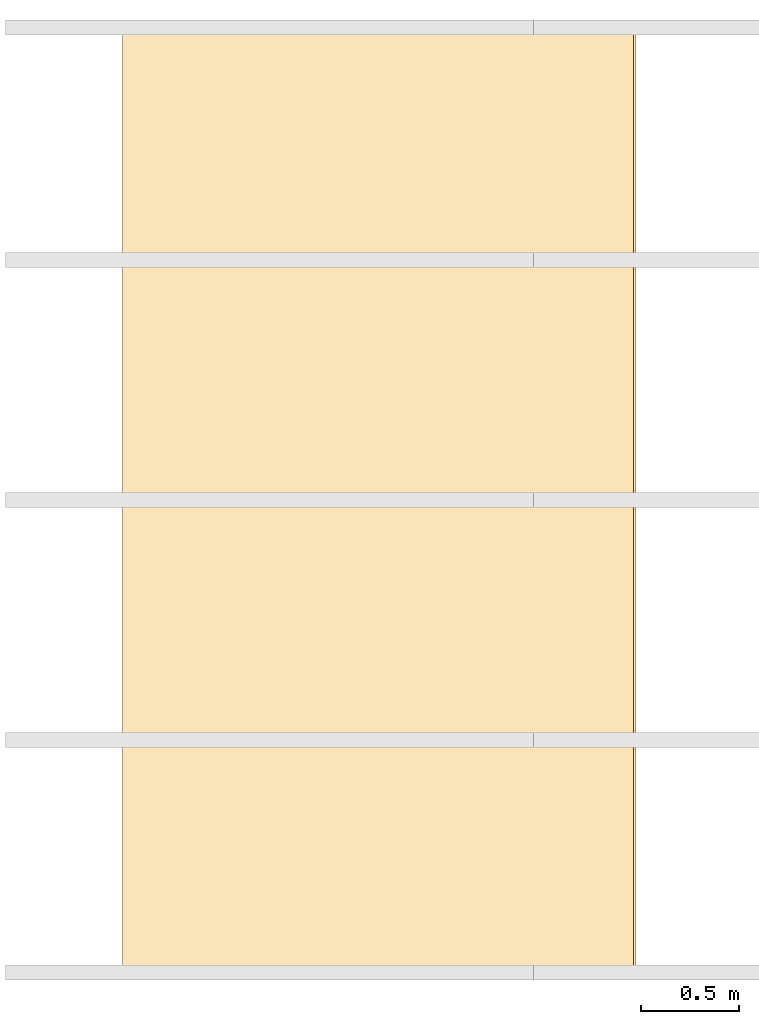
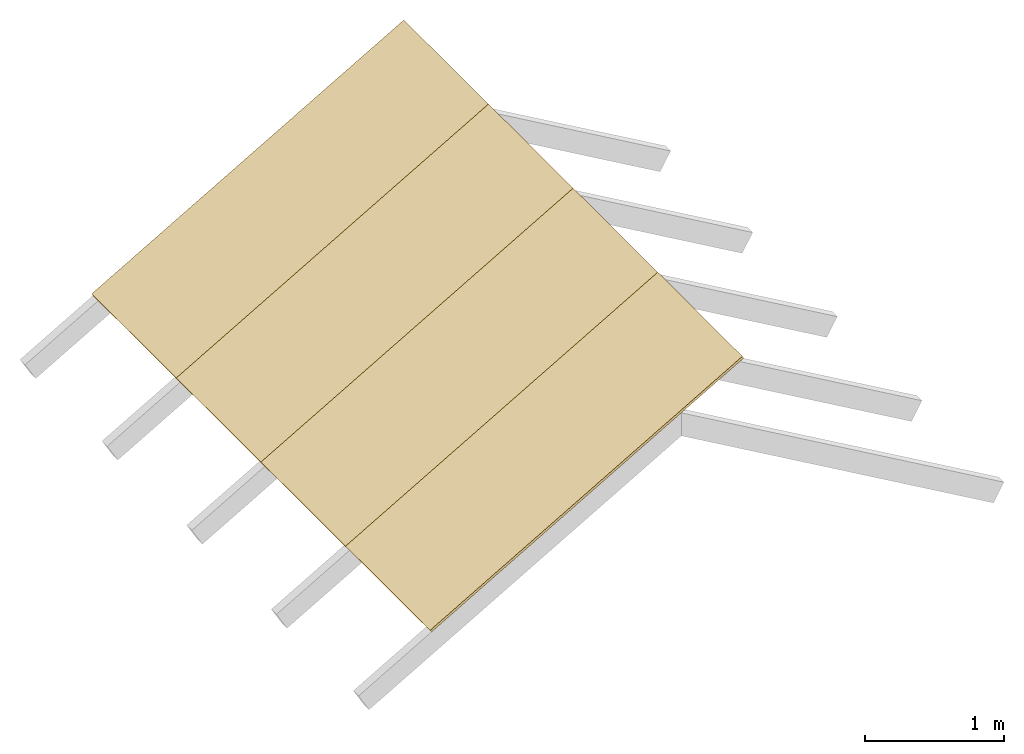
# One storey, part 2 of 2: 4 coverings.
"""IFC4 building model written with IfcOpenShell, lengths in millimetres."""

from ifc_helpers import new_model, entity, si_unit, converted_unit, frame, frame_2d, origin_with_axes, place, context, subcontext, project, spatial, rectangle, extrude, material, material_profile, profile_set, profile_usage, type_object, element, save


model = new_model("IFC4")

# Units and contexts
model_context = context("Model", 3, precision=1e-05, world=origin_with_axes())
plan_context = context("Plan", 2, precision=1e-05, world=frame_2d((0.0, 0.0, 0.0), x_axis=(1.0, 0.0, 0.0)))
body_context = subcontext(model_context, "Body", "Model", "MODEL_VIEW")
ifc_project = project(units=[converted_unit("PLANEANGLEUNIT", "degree", entity("IfcReal", 0.0174532925199433), si_unit("PLANEANGLEUNIT", "RADIAN"), dimensions=[0, 0, 0, 0, 0, 0, 0]), si_unit("AREAUNIT", "SQUARE_METRE", prefix="MILLI"), si_unit("VOLUMEUNIT", "CUBIC_METRE", prefix="MILLI"), si_unit("LENGTHUNIT", "METRE", prefix="MILLI")], contexts=[model_context, plan_context])

# Site, building, storey
site_placement = place(None, origin_with_axes())
site = spatial("IfcSite", under=ifc_project, at=site_placement)
building_placement = place(site_placement, origin_with_axes())
building = spatial("IfcBuilding", under=site, at=building_placement, Name="Building")
storey_placement = place(building_placement, origin_with_axes())
storey = spatial("IfcBuildingStorey", under=building, at=storey_placement, Name="Storey")

# Coverings
ifc_material = material(Name="underlayment")
ifc_material_profile = material_profile(ifc_material, rectangle(XDim=1220.0, YDim=22.0))
ifc_profile_set = profile_set([ifc_material_profile])
ifc_profile_usage_1 = profile_usage(ifc_profile_set, cardinal=1)
covering_type = type_object("IfcCoveringType", Name="underlayment_2440x1220x22mm", PredefinedType="CLADDING", material=ifc_profile_set)
covering_1_placement = place(storey_placement, frame((519.615054130554, 1145.00021934509, 502.073228359222), z_axis=(0.866025686264038, 8.06965587685227e-08, 0.499999552965164), x_axis=(-1.62920684942947e-07, 1.0, 1.20793970381783e-07)))
element("IfcCovering", 1, at=covering_1_placement, inside=storey, type_object=covering_type, material=ifc_profile_usage_1, Name="Covering", PredefinedType="NOTDEFINED", context=body_context, shape_type="SweptSolid", body=[
    extrude(rectangle(XDim=1220.0, YDim=22.0), frame((-610.0, 11.0, 0.0), z_axis=(0.0, 0.0, 1.0), x_axis=(1.0, 0.0, 0.0)), (0.0, 0.0, 1.0), 3000.0),
])
ifc_profile_usage_2 = profile_usage(ifc_profile_set, cardinal=1)
covering_2_placement = place(storey_placement, frame((519.614815711975, 2365.00024795532, 502.073347568512), z_axis=(0.866025686264038, 8.06965587685227e-08, 0.499999552965164), x_axis=(-1.62920684942947e-07, 1.0, 1.20793970381783e-07)))
element("IfcCovering", 2, at=covering_2_placement, inside=storey, type_object=covering_type, material=ifc_profile_usage_2, Name="Covering", PredefinedType="NOTDEFINED", context=body_context, shape_type="SweptSolid", body=[
    extrude(rectangle(XDim=1220.0, YDim=22.0), frame((-610.0, 11.0, 0.0), z_axis=(0.0, 0.0, 1.0), x_axis=(1.0, 0.0, 0.0)), (0.0, 0.0, 1.0), 3000.0),
])
ifc_profile_usage_3 = profile_usage(ifc_profile_set, cardinal=1)
covering_3_placement = place(storey_placement, frame((519.614517688751, 3585.00003814697, 502.073585987091), z_axis=(0.866025686264038, 8.06965587685227e-08, 0.499999552965164), x_axis=(-1.62920684942947e-07, 1.0, 1.20793970381783e-07)))
element("IfcCovering", 3, at=covering_3_placement, inside=storey, type_object=covering_type, material=ifc_profile_usage_3, Name="Covering", PredefinedType="NOTDEFINED", context=body_context, shape_type="SweptSolid", body=[
    extrude(rectangle(XDim=1220.0, YDim=22.0), frame((-610.0, 11.0, 0.0), z_axis=(0.0, 0.0, 1.0), x_axis=(1.0, 0.0, 0.0)), (0.0, 0.0, 1.0), 3000.0),
])
ifc_profile_usage_4 = profile_usage(ifc_profile_set, cardinal=1)
covering_4_placement = place(storey_placement, frame((519.614040851593, 4804.99982833862, 502.073764801025), z_axis=(0.866025686264038, 8.06965587685227e-08, 0.499999552965164), x_axis=(-1.62920684942947e-07, 1.0, 1.20793970381783e-07)))
element("IfcCovering", 4, at=covering_4_placement, inside=storey, type_object=covering_type, material=ifc_profile_usage_4, Name="Covering", PredefinedType="NOTDEFINED", context=body_context, shape_type="SweptSolid", body=[
    extrude(rectangle(XDim=1220.0, YDim=22.0), frame((-610.0, 11.0, 0.0), z_axis=(0.0, 0.0, 1.0), x_axis=(1.0, 0.0, 0.0)), (0.0, 0.0, 1.0), 3000.0),
])

save(model, "model.ifc")
